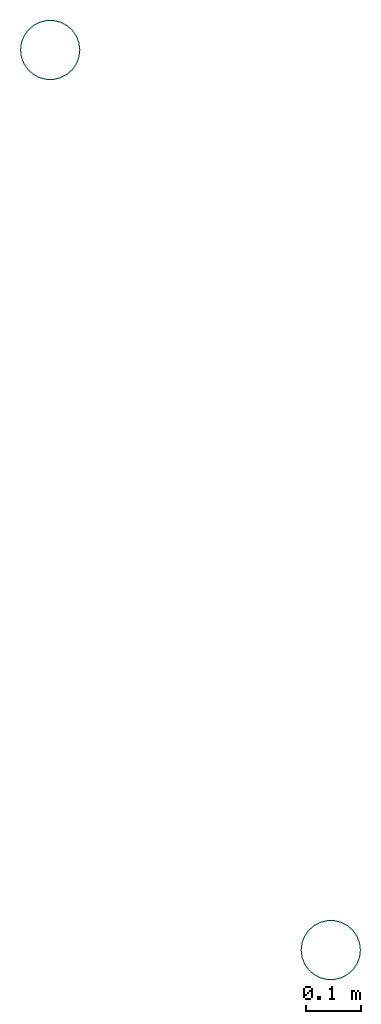
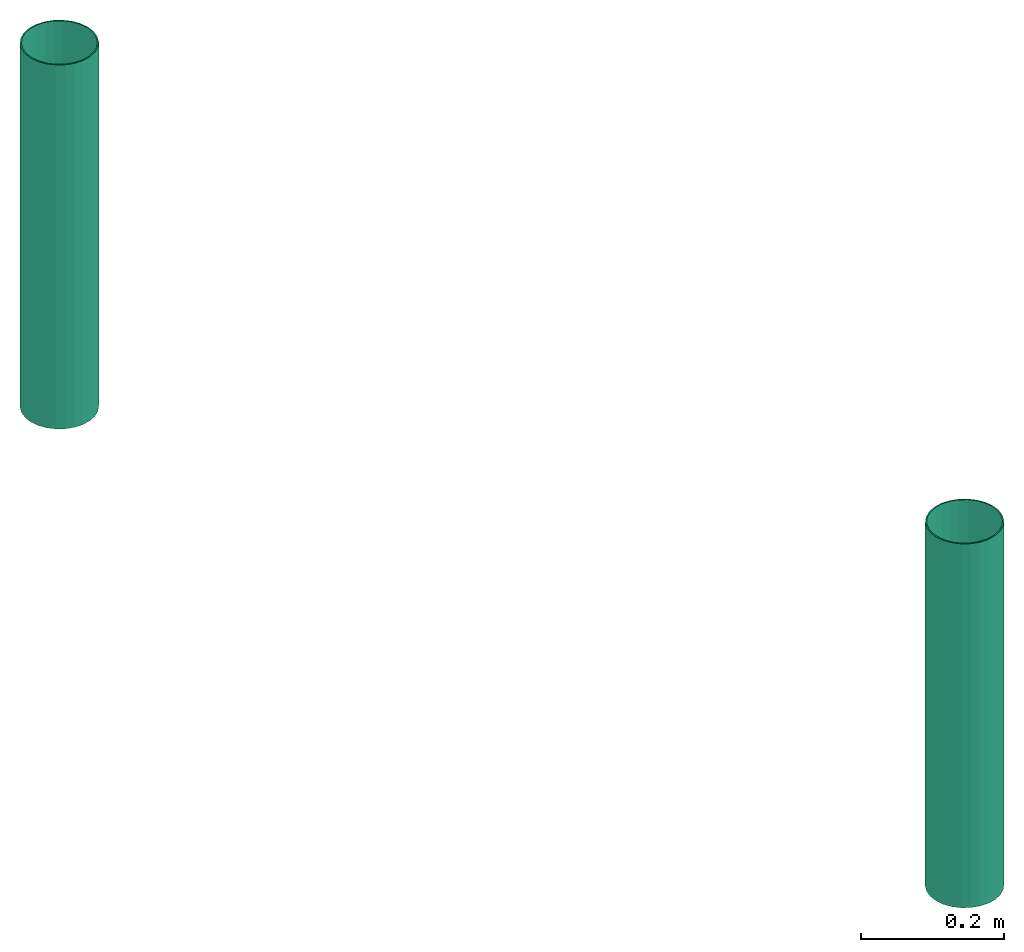
# One storey: 2 flow segments.
"""IFC2X3 building model written with IfcOpenShell, lengths in metres."""

from ifc_helpers import new_model, entity, si_unit, converted_unit, derived_unit, direction, frame, origin_with_axes, origin_2d_with_axis, place, context, project, spatial, hollow_circle, extrude, material, type_object, element, save


model = new_model("IFC2X3")

# Units and contexts
model_context = context("Model", 3, precision=1e-05, world=origin_with_axes(), true_north=direction((-0.4480736161291701, 0.8939966636005579, 0.0)), identifier="Body")
ifc_project = project(units=[si_unit("LENGTHUNIT", "METRE"), si_unit("AREAUNIT", "SQUARE_METRE"), si_unit("ELECTRICCURRENTUNIT", "AMPERE"), si_unit("ELECTRICVOLTAGEUNIT", "VOLT"), si_unit("ELECTRICRESISTANCEUNIT", "OHM"), si_unit("POWERUNIT", "WATT"), si_unit("MASSUNIT", "GRAM"), si_unit("SOLIDANGLEUNIT", "STERADIAN"), si_unit("THERMODYNAMICTEMPERATUREUNIT", "DEGREE_CELSIUS"), si_unit("PRESSUREUNIT", "PASCAL"), si_unit("LUMINOUSFLUXUNIT", "LUMEN"), si_unit("ILLUMINANCEUNIT", "LUX"), si_unit("FREQUENCYUNIT", "HERTZ"), si_unit("VOLUMEUNIT", "CUBIC_METRE"), si_unit("TIMEUNIT", "SECOND"), derived_unit("VOLUMETRICFLOWRATEUNIT", [(si_unit("TIMEUNIT", "SECOND"), -1), (si_unit("VOLUMEUNIT", "CUBIC_METRE"), 1)]), derived_unit("THERMALTRANSMITTANCEUNIT", [(si_unit("AREAUNIT", "SQUARE_METRE"), -1), (si_unit("THERMODYNAMICTEMPERATUREUNIT", "KELVIN"), -1), (si_unit("POWERUNIT", "WATT"), 1)]), converted_unit("PLANEANGLEUNIT", "DEGREE", entity("IfcPlaneAngleMeasure", 0.0174532925199433), si_unit("PLANEANGLEUNIT", "RADIAN"), dimensions=[0, 0, 0, 0, 0, 0, 0])], contexts=[model_context])

# Site, building, storey
site_placement = place(None, origin_with_axes())
site = spatial("IfcSite", under=ifc_project, at=site_placement, CompositionType="ELEMENT")
building_placement = place(site_placement, origin_with_axes())
building = spatial("IfcBuilding", under=site, at=building_placement, Name="Duplex House", CompositionType="ELEMENT")
storey_placement = place(building_placement, frame((0.0, 0.0, 5.9), z_axis=(0.0, 0.0, 1.0), x_axis=(1.0, 0.0, 0.0)))
storey = spatial("IfcBuildingStorey", under=building, at=storey_placement, Name="Roof", CompositionType="ELEMENT", Elevation=5.9)

# Flow segments
ifc_material = material()
pipe_segment_type = type_object("IfcPipeSegmentType", PredefinedType="RIGIDSEGMENT")
for number, where, z_axis, x_axis in (
    (1, (-25.7138786315918, -7.988743782043457, 0.300000011920929), (-1.0, 0.0, 0.0), (0.0, 0.0, -1.0)),
    (2, (-26.22540283203125, -6.347939491271973, 0.300000011920929), (-1.0, 0.0, 0.0), (0.0, 0.0, -1.0)),
):
    element("IfcFlowSegment", number, at=place(storey_placement, frame(where, z_axis=z_axis, x_axis=x_axis)), inside=storey, type_object=pipe_segment_type, material=ifc_material, context=model_context, shape_type="SweptSolid", body=[
        extrude(hollow_circle(Radius=0.055, WallThickness=0.002, at=origin_2d_with_axis()), frame((0.0, 0.0, 0.0), z_axis=(1.0, 0.0, 6.123233995736766e-17), x_axis=(6.123233995736766e-17, 0.0, -1.0)), (0.0, 0.0, 1.0), 0.6200000047683716),
    ])

save(model, "model.ifc")
